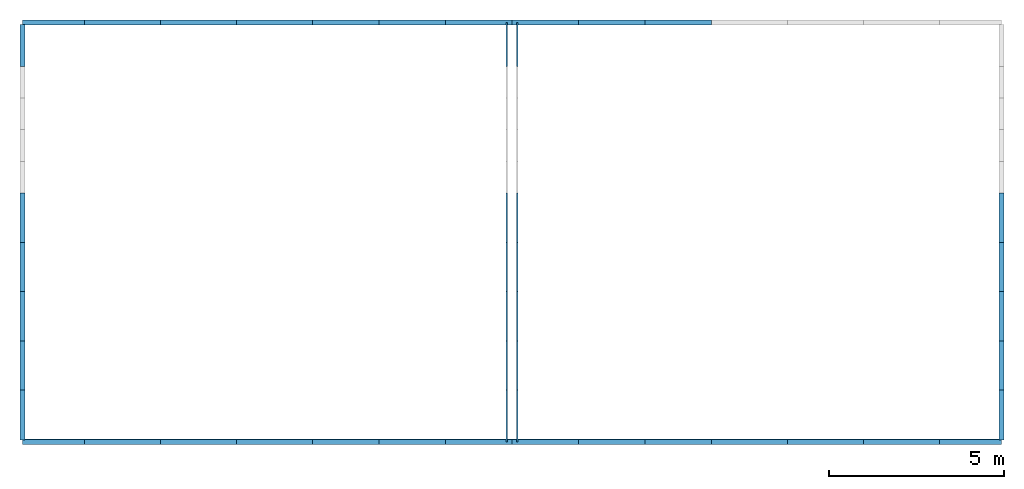
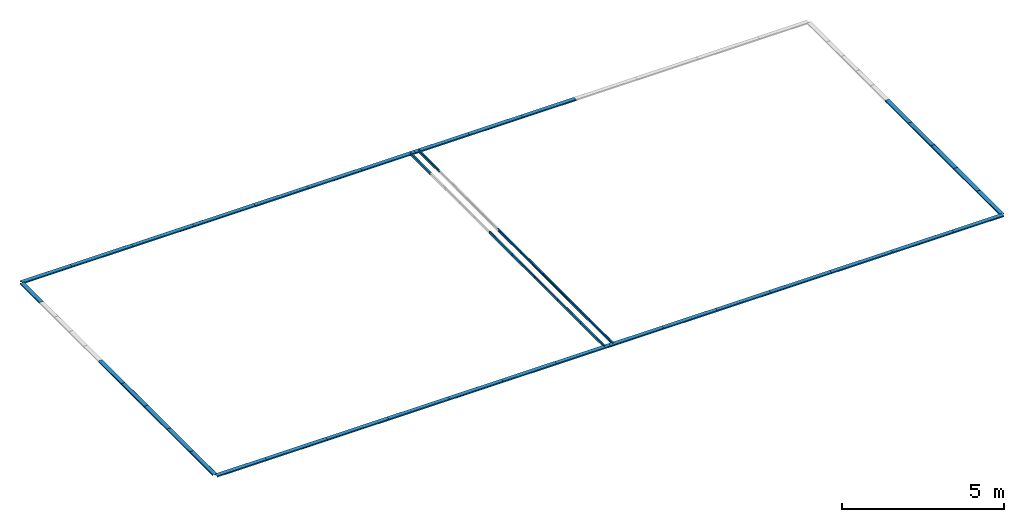
# One storey, part 1 of 2: 47 beams.
"""IFC4 building model written with IfcOpenShell, lengths in metres."""

import ifcopenshell
import ifcopenshell.guid

model = None  # the IFC model being written
_history = None  # IfcOwnerHistory: only IFC2X3 demands one
_inside = {}  # id of a spatial element -> (the spatial element, [elements in it])
_under = {}  # id of a project, library or spatial element -> (it, [spatial elements below it])
_declared = {}  # id of a project -> (the project, [libraries it declares])
_typed = {}  # id of a type object -> (the type object, [elements of that type])
_made_of = {}  # id of a material, layer set ... -> (it, [elements and type objects made of it])


def new_model(schema):
    """Start an empty IFC model of exactly this schema.

    Asked for "IFC4X3", IfcOpenShell would pick the latest addendum, in which some entities
    have other attributes; the version numbers below select the first issue.
    IFC2X3 requires an IfcOwnerHistory on every rooted entity: one is made here for all.
    """
    global model, _history
    if schema == "IFC4X3":
        model = ifcopenshell.file(schema_version=(4, 3, 0, 0))
    else:
        model = ifcopenshell.file(schema=schema)
    _inside.clear()
    _under.clear()
    _declared.clear()
    _typed.clear()
    _made_of.clear()
    _history = None
    if model.schema == "IFC2X3":
        org = make("IfcOrganization", Name="unknown")
        user = make(
            "IfcPersonAndOrganization",
            ThePerson=make("IfcPerson", FamilyName="unknown"),
            TheOrganization=org,
        )
        app = make(
            "IfcApplication",
            ApplicationDeveloper=org,
            Version="unknown",
            ApplicationFullName="unknown",
            ApplicationIdentifier="unknown",
        )
        _history = make(
            "IfcOwnerHistory",
            OwningUser=user,
            OwningApplication=app,
            ChangeAction="ADDED",
            CreationDate=0,
        )
    return model


def make(cls, **values):
    """One entity of the class cls with the attributes given. An attribute that is None is left unset."""
    return model.create_entity(
        cls, **{name: value for name, value in values.items() if value is not None}
    )


def rooted(cls, **values):
    """An entity with a GlobalId (a new one), such as an element, a storey or a relation."""
    return make(cls, GlobalId=ifcopenshell.guid.new(), OwnerHistory=_history, **values)


def si_unit(unit_type, name, prefix=None):
    """IfcSIUnit, for example si_unit("LENGTHUNIT", "METRE", prefix="MILLI")."""
    return make("IfcSIUnit", UnitType=unit_type, Prefix=prefix, Name=name)


def derived_unit(unit_type, elements):
    """IfcDerivedUnit: a product of units, each with its exponent."""
    return make(
        "IfcDerivedUnit",
        Elements=[
            make("IfcDerivedUnitElement", Unit=unit, Exponent=power)
            for unit, power in elements
        ],
        UnitType=unit_type,
    )


def assignment(units):
    """IfcUnitAssignment: the units of a project."""
    return None if units is None else make("IfcUnitAssignment", Units=units)


def point(xyz):
    """IfcCartesianPoint."""
    return None if xyz is None else make("IfcCartesianPoint", Coordinates=xyz)


def direction(xyz):
    """IfcDirection."""
    return None if xyz is None else make("IfcDirection", DirectionRatios=xyz)


def frame(location, z_axis=None, x_axis=None):
    """IfcAxis2Placement3D, a coordinate frame: its origin and axes. An axis left out is left unset."""
    return make(
        "IfcAxis2Placement3D",
        Location=point(location),
        Axis=direction(z_axis),
        RefDirection=direction(x_axis),
    )


def frame_2d(location, x_axis=None):
    """IfcAxis2Placement2D, a coordinate frame in the plane: its origin and x axis."""
    return make(
        "IfcAxis2Placement2D", Location=point(location), RefDirection=direction(x_axis)
    )


def origin_with_axes():
    """The frame at (0, 0, 0) with the z axis (0, 0, 1) and the x axis (1, 0, 0) written out."""
    return frame((0.0, 0.0, 0.0), z_axis=(0.0, 0.0, 1.0), x_axis=(1.0, 0.0, 0.0))


def origin_2d_with_axis():
    """The frame at (0, 0) in the plane with the x axis (1, 0) written out."""
    return frame_2d((0.0, 0.0), x_axis=(1.0, 0.0))


def place(relative_to, where):
    """IfcLocalPlacement: puts the frame where relative to a parent placement (None: the world)."""
    return make(
        "IfcLocalPlacement", PlacementRelTo=relative_to, RelativePlacement=where
    )


def context(
    kind, dimensions, precision=None, world=None, true_north=None, identifier=None
):
    """IfcGeometricRepresentationContext, for example the 3D "Model" context."""
    return make(
        "IfcGeometricRepresentationContext",
        ContextIdentifier=identifier,
        ContextType=kind,
        CoordinateSpaceDimension=dimensions,
        Precision=precision,
        WorldCoordinateSystem=world,
        TrueNorth=true_north,
    )


def project(units=None, contexts=None):
    """IfcProject with its units and contexts."""
    return rooted(
        "IfcProject",
        Name="project",
        RepresentationContexts=contexts,
        UnitsInContext=assignment(units),
    )


def spatial(cls, under=None, at=None, **own):
    """A site, building, storey or space (cls), placed at a placement, below another one or the project."""
    s = rooted(cls, ObjectPlacement=at, **own)
    if under is not None:
        _under.setdefault(under.id(), (under, []))[1].append(s)
    return s


def profile(cls, at=None, kind="AREA", **sizes):
    """A parametric profile (cls). Its sizes go by their IFC names, for example OverallWidth=200.0."""
    return make(cls, ProfileType=kind, Position=at, **sizes)


def c_section(**sizes):
    """IfcCShapeProfileDef."""
    return profile("IfcCShapeProfileDef", **sizes)


def extrude(swept, where, along, depth):
    """IfcExtrudedAreaSolid: the profile swept, set in the frame where, extruded along a direction by depth."""
    return make(
        "IfcExtrudedAreaSolid",
        SweptArea=swept,
        Position=where,
        ExtrudedDirection=direction(along),
        Depth=depth,
    )


def shape(context_of_items, identifier, shape_type, items):
    """IfcShapeRepresentation: the items that make up one representation, for example the "Body"."""
    return make(
        "IfcShapeRepresentation",
        ContextOfItems=context_of_items,
        RepresentationIdentifier=identifier,
        RepresentationType=shape_type,
        Items=items,
    )


def material(Name=None, Category=None):
    """IfcMaterial."""
    return make("IfcMaterial", Name=Name, Category=Category)


def material_profile(
    of_material, cross_section, Name=None, Category=None, Priority=None
):
    """IfcMaterialProfile: a cross section and its material."""
    return make(
        "IfcMaterialProfile",
        Name=Name,
        Material=of_material,
        Profile=cross_section,
        Priority=Priority,
        Category=Category,
    )


def profile_set(profiles, Name=None, composite=None):
    """IfcMaterialProfileSet."""
    return make(
        "IfcMaterialProfileSet",
        Name=Name,
        MaterialProfiles=profiles,
        CompositeProfile=composite,
    )


def profile_usage(for_profile_set, cardinal=None, extent=None):
    """IfcMaterialProfileSetUsage: how a profile set lies along its element."""
    return make(
        "IfcMaterialProfileSetUsage",
        ForProfileSet=for_profile_set,
        CardinalPoint=cardinal,
        ReferenceExtent=extent,
    )


def made_of(thing, what):
    """Note that an element or type object is made of a material, layer set ...; save() writes the relation."""
    if what is not None:
        _made_of.setdefault(what.id(), (what, []))[1].append(thing)
    return thing


def element(
    cls,
    number,
    at=None,
    inside=None,
    cuts=None,
    type_object=None,
    material=None,
    context=None,
    identifier="Body",
    shape_type=None,
    held_by="IfcProductDefinitionShape",
    body=None,
    shapes=None,
    **own,
):
    """One element of the class cls, such as IfcWall. Its Tag is "e" and its number.

    at: its placement. inside: the storey or other place that contains it. cuts: it is an
    opening in that element (IfcRelVoidsElement). A single representation is given by context,
    identifier, shape_type and body (its items); several are given by shapes. held_by: the class
    of the entity that holds the representations. save() writes the other relations.
    """
    e = rooted(cls, Tag="e%d" % number, ObjectPlacement=at, **own)
    if body is not None:
        shapes = [shape(context, identifier, shape_type, body)]
    if shapes is not None:
        e.Representation = make(held_by, Representations=shapes)
    if inside is not None:
        _inside.setdefault(inside.id(), (inside, []))[1].append(e)
    if cuts is not None:
        rooted(
            "IfcRelVoidsElement", RelatingBuildingElement=cuts, RelatedOpeningElement=e
        )
    if type_object is not None:
        _typed.setdefault(type_object.id(), (type_object, []))[1].append(e)
    return made_of(e, material)


def aggregate(whole, parts):
    """IfcRelAggregates: a whole, such as a stair, and the parts it consists of."""
    return rooted("IfcRelAggregates", RelatingObject=whole, RelatedObjects=parts)


def save(model, path):
    """Write the relations noted so far, then the file.

    IfcRelAggregates (storeys below a building ...), IfcRelContainedInSpatialStructure (elements
    in a storey), IfcRelDefinesByType, IfcRelAssociatesMaterial and IfcRelDeclares: one each for
    every whole, place, type object, material and project.
    """
    for whole, parts in _under.values():
        aggregate(whole, parts)
    for where, things in _inside.values():
        rooted(
            "IfcRelContainedInSpatialStructure",
            RelatedElements=things,
            RelatingStructure=where,
        )
    for kind, things in _typed.values():
        rooted("IfcRelDefinesByType", RelatedObjects=things, RelatingType=kind)
    for what, things in _made_of.values():
        rooted("IfcRelAssociatesMaterial", RelatedObjects=things, RelatingMaterial=what)
    for by, libraries in _declared.values():
        rooted("IfcRelDeclares", RelatingContext=by, RelatedDefinitions=libraries)
    model.write(path)


model = new_model("IFC4")

# Units and contexts
model_context = context("Model", 3, world=origin_with_axes())
ifc_project = project(units=[si_unit("LENGTHUNIT", "METRE"), si_unit("AREAUNIT", "SQUARE_METRE"), si_unit("VOLUMEUNIT", "CUBIC_METRE"), derived_unit("SECTIONMODULUSUNIT", [(si_unit("LENGTHUNIT", "METRE"), 3)]), derived_unit("MOMENTOFINERTIAUNIT", [(si_unit("LENGTHUNIT", "METRE"), 4)]), si_unit("PLANEANGLEUNIT", "RADIAN"), si_unit("TIMEUNIT", "SECOND"), si_unit("THERMODYNAMICTEMPERATUREUNIT", "DEGREE_CELSIUS"), derived_unit("THERMALEXPANSIONCOEFFICIENTUNIT", [(si_unit("THERMODYNAMICTEMPERATUREUNIT", "DEGREE_CELSIUS"), -1)])], contexts=[model_context])

# Site, building, storey
site = spatial("IfcSite", under=ifc_project, CompositionType="ELEMENT")
building = spatial("IfcBuilding", under=site, Name="Building", CompositionType="ELEMENT")
storey = spatial("IfcBuildingStorey", under=building, Name="TOP LEVEL", CompositionType="ELEMENT", Elevation=9.9498)

# Beams
ifc_material = material(Name="SAE 1020")
ifc_material_profile_1 = material_profile(ifc_material, c_section(Depth=0.1, Width=0.05, WallThickness=0.003, Girth=0.017, InternalFilletRadius=0.003, at=origin_2d_with_axis()))
ifc_profile_set_1 = profile_set([ifc_material_profile_1])
ifc_profile_usage_1 = profile_usage(ifc_profile_set_1, cardinal=10)
beam_1_placement = place(None, frame((15.1, 8.75, 9.9441), z_axis=(3.3783784e-07, 1.0, -3.0405405e-05), x_axis=(0.9992562, 8.3491316e-07, 0.038562213)))
element("IfcBeam", 1, at=beam_1_placement, inside=storey, material=ifc_profile_usage_1, Name="60", context=model_context, shape_type="SweptSolid", body=[
    extrude(c_section(Depth=0.1, Width=0.05, WallThickness=0.003, Girth=0.017, InternalFilletRadius=0.003, at=origin_2d_with_axis()), origin_with_axes(), (0.0, 0.0, 1.0), 1.48),
])
ifc_material_profile_2 = material_profile(ifc_material, c_section(Depth=0.1, Width=0.05, WallThickness=0.003, Girth=0.017, InternalFilletRadius=0.003, at=origin_2d_with_axis()))
ifc_profile_set_2 = profile_set([ifc_material_profile_2])
ifc_profile_usage_2 = profile_usage(ifc_profile_set_2, cardinal=10)
beam_2_placement = place(None, frame((15.1, 19.5, 9.9441136), z_axis=(3.3783784e-07, 1.0, -3.0405405e-05), x_axis=(0.9992562, 8.3491316e-07, 0.038562213)))
element("IfcBeam", 2, at=beam_2_placement, inside=storey, material=ifc_profile_usage_2, Name="65", context=model_context, shape_type="SweptSolid", body=[
    extrude(c_section(Depth=0.1, Width=0.05, WallThickness=0.003, Girth=0.017, InternalFilletRadius=0.003, at=origin_2d_with_axis()), origin_with_axes(), (0.0, 0.0, 1.0), 1.25),
])
ifc_material_profile_3 = material_profile(ifc_material, c_section(Depth=0.1, Width=0.05, WallThickness=0.003, Girth=0.017, InternalFilletRadius=0.003, at=origin_2d_with_axis()))
ifc_profile_set_3 = profile_set([ifc_material_profile_3])
ifc_profile_usage_3 = profile_usage(ifc_profile_set_3, cardinal=10)
beam_3_placement = place(None, frame((15.4, 8.75, 9.9441), z_axis=(3.3783784e-07, 1.0, -3.0405405e-05), x_axis=(-0.9992562, 8.3491316e-07, 0.038562213)))
element("IfcBeam", 3, at=beam_3_placement, inside=storey, material=ifc_profile_usage_3, Name="180", context=model_context, shape_type="SweptSolid", body=[
    extrude(c_section(Depth=0.1, Width=0.05, WallThickness=0.003, Girth=0.017, InternalFilletRadius=0.003, at=origin_2d_with_axis()), origin_with_axes(), (0.0, 0.0, 1.0), 1.48),
])
ifc_material_profile_4 = material_profile(ifc_material, c_section(Depth=0.1, Width=0.05, WallThickness=0.003, Girth=0.017, InternalFilletRadius=0.003, at=origin_2d_with_axis()))
ifc_profile_set_4 = profile_set([ifc_material_profile_4])
ifc_profile_usage_4 = profile_usage(ifc_profile_set_4, cardinal=10)
beam_4_placement = place(None, frame((15.4, 19.5, 9.9441136), z_axis=(3.3783784e-07, 1.0, -3.0405405e-05), x_axis=(-0.9992562, 8.3491316e-07, 0.038562213)))
element("IfcBeam", 4, at=beam_4_placement, inside=storey, material=ifc_profile_usage_4, Name="185", context=model_context, shape_type="SweptSolid", body=[
    extrude(c_section(Depth=0.1, Width=0.05, WallThickness=0.003, Girth=0.017, InternalFilletRadius=0.003, at=origin_2d_with_axis()), origin_with_axes(), (0.0, 0.0, 1.0), 1.25),
])
ifc_material_profile_5 = material_profile(ifc_material, c_section(Depth=0.1, Width=0.05, WallThickness=0.003, Girth=0.017, InternalFilletRadius=0.003, at=origin_2d_with_axis()))
ifc_profile_set_5 = profile_set([ifc_material_profile_5])
ifc_profile_usage_5 = profile_usage(ifc_profile_set_5, cardinal=10)
beam_5_placement = place(None, frame((15.1, 10.23, 9.9441004), z_axis=(3.3783784e-07, 1.0, -3.0405405e-05), x_axis=(0.9992562, 8.3491316e-07, 0.038562213)))
element("IfcBeam", 5, at=beam_5_placement, inside=storey, material=ifc_profile_usage_5, Name="508", context=model_context, shape_type="SweptSolid", body=[
    extrude(c_section(Depth=0.1, Width=0.05, WallThickness=0.003, Girth=0.017, InternalFilletRadius=0.003, at=origin_2d_with_axis()), origin_with_axes(), (0.0, 0.0, 1.0), 1.41),
])
ifc_material_profile_6 = material_profile(ifc_material, c_section(Depth=0.1, Width=0.05, WallThickness=0.003, Girth=0.017, InternalFilletRadius=0.003, at=origin_2d_with_axis()))
ifc_profile_set_6 = profile_set([ifc_material_profile_6])
ifc_profile_usage_6 = profile_usage(ifc_profile_set_6, cardinal=10)
beam_6_placement = place(None, frame((15.1, 11.64, 9.9441004), z_axis=(3.3783784e-07, 1.0, -3.0405405e-05), x_axis=(0.9992562, 8.3491316e-07, 0.038562213)))
element("IfcBeam", 6, at=beam_6_placement, inside=storey, material=ifc_profile_usage_6, Name="509", context=model_context, shape_type="SweptSolid", body=[
    extrude(c_section(Depth=0.1, Width=0.05, WallThickness=0.003, Girth=0.017, InternalFilletRadius=0.003, at=origin_2d_with_axis()), origin_with_axes(), (0.0, 0.0, 1.0), 1.41),
])
ifc_material_profile_7 = material_profile(ifc_material, c_section(Depth=0.1, Width=0.05, WallThickness=0.003, Girth=0.017, InternalFilletRadius=0.003, at=origin_2d_with_axis()))
ifc_profile_set_7 = profile_set([ifc_material_profile_7])
ifc_profile_usage_7 = profile_usage(ifc_profile_set_7, cardinal=10)
beam_7_placement = place(None, frame((15.1, 13.05, 9.9441004), z_axis=(3.3783784e-07, 1.0, -3.0405405e-05), x_axis=(0.9992562, 8.3491316e-07, 0.038562213)))
element("IfcBeam", 7, at=beam_7_placement, inside=storey, material=ifc_profile_usage_7, Name="511", context=model_context, shape_type="SweptSolid", body=[
    extrude(c_section(Depth=0.1, Width=0.05, WallThickness=0.003, Girth=0.017, InternalFilletRadius=0.003, at=origin_2d_with_axis()), origin_with_axes(), (0.0, 0.0, 1.0), 1.41),
])
ifc_material_profile_8 = material_profile(ifc_material, c_section(Depth=0.1, Width=0.05, WallThickness=0.003, Girth=0.017, InternalFilletRadius=0.003, at=origin_2d_with_axis()))
ifc_profile_set_8 = profile_set([ifc_material_profile_8])
ifc_profile_usage_8 = profile_usage(ifc_profile_set_8, cardinal=10)
beam_8_placement = place(None, frame((15.1, 14.46, 9.9441004), z_axis=(3.3783784e-07, 1.0, -3.0405405e-05), x_axis=(0.9992562, 8.3491316e-07, 0.038562213)))
element("IfcBeam", 8, at=beam_8_placement, inside=storey, material=ifc_profile_usage_8, Name="514", context=model_context, shape_type="SweptSolid", body=[
    extrude(c_section(Depth=0.1, Width=0.05, WallThickness=0.003, Girth=0.017, InternalFilletRadius=0.003, at=origin_2d_with_axis()), origin_with_axes(), (0.0, 0.0, 1.0), 1.41),
])
ifc_material_profile_9 = material_profile(ifc_material, c_section(Depth=0.1, Width=0.05, WallThickness=0.003, Girth=0.017, InternalFilletRadius=0.003, at=origin_2d_with_axis()))
ifc_profile_set_9 = profile_set([ifc_material_profile_9])
ifc_profile_usage_9 = profile_usage(ifc_profile_set_9, cardinal=10)
beam_9_placement = place(None, frame((15.4, 10.23, 9.9441004), z_axis=(3.3783784e-07, 1.0, -3.0405405e-05), x_axis=(-0.9992562, 8.3491316e-07, 0.038562213)))
element("IfcBeam", 9, at=beam_9_placement, inside=storey, material=ifc_profile_usage_9, Name="1011", context=model_context, shape_type="SweptSolid", body=[
    extrude(c_section(Depth=0.1, Width=0.05, WallThickness=0.003, Girth=0.017, InternalFilletRadius=0.003, at=origin_2d_with_axis()), origin_with_axes(), (0.0, 0.0, 1.0), 1.41),
])
ifc_material_profile_10 = material_profile(ifc_material, c_section(Depth=0.1, Width=0.05, WallThickness=0.003, Girth=0.017, InternalFilletRadius=0.003, at=origin_2d_with_axis()))
ifc_profile_set_10 = profile_set([ifc_material_profile_10])
ifc_profile_usage_10 = profile_usage(ifc_profile_set_10, cardinal=10)
beam_10_placement = place(None, frame((15.4, 11.64, 9.9441004), z_axis=(3.3783784e-07, 1.0, -3.0405405e-05), x_axis=(-0.9992562, 8.3491316e-07, 0.038562213)))
element("IfcBeam", 10, at=beam_10_placement, inside=storey, material=ifc_profile_usage_10, Name="1012", context=model_context, shape_type="SweptSolid", body=[
    extrude(c_section(Depth=0.1, Width=0.05, WallThickness=0.003, Girth=0.017, InternalFilletRadius=0.003, at=origin_2d_with_axis()), origin_with_axes(), (0.0, 0.0, 1.0), 1.41),
])
ifc_material_profile_11 = material_profile(ifc_material, c_section(Depth=0.1, Width=0.05, WallThickness=0.003, Girth=0.017, InternalFilletRadius=0.003, at=origin_2d_with_axis()))
ifc_profile_set_11 = profile_set([ifc_material_profile_11])
ifc_profile_usage_11 = profile_usage(ifc_profile_set_11, cardinal=10)
beam_11_placement = place(None, frame((15.4, 13.05, 9.9441004), z_axis=(3.3783784e-07, 1.0, -3.0405405e-05), x_axis=(-0.9992562, 8.3491316e-07, 0.038562213)))
element("IfcBeam", 11, at=beam_11_placement, inside=storey, material=ifc_profile_usage_11, Name="1013", context=model_context, shape_type="SweptSolid", body=[
    extrude(c_section(Depth=0.1, Width=0.05, WallThickness=0.003, Girth=0.017, InternalFilletRadius=0.003, at=origin_2d_with_axis()), origin_with_axes(), (0.0, 0.0, 1.0), 1.41),
])
ifc_material_profile_12 = material_profile(ifc_material, c_section(Depth=0.1, Width=0.05, WallThickness=0.003, Girth=0.017, InternalFilletRadius=0.003, at=origin_2d_with_axis()))
ifc_profile_set_12 = profile_set([ifc_material_profile_12])
ifc_profile_usage_12 = profile_usage(ifc_profile_set_12, cardinal=10)
beam_12_placement = place(None, frame((15.4, 14.46, 9.9441004), z_axis=(3.3783784e-07, 1.0, -3.0405405e-05), x_axis=(-0.9992562, 8.3491316e-07, 0.038562213)))
element("IfcBeam", 12, at=beam_12_placement, inside=storey, material=ifc_profile_usage_12, Name="1014", context=model_context, shape_type="SweptSolid", body=[
    extrude(c_section(Depth=0.1, Width=0.05, WallThickness=0.003, Girth=0.017, InternalFilletRadius=0.003, at=origin_2d_with_axis()), origin_with_axes(), (0.0, 0.0, 1.0), 1.41),
])
ifc_material_profile_13 = material_profile(ifc_material, c_section(Depth=0.15, Width=0.05, WallThickness=0.003, Girth=0.017, InternalFilletRadius=0.003, at=origin_2d_with_axis()))
ifc_profile_set_13 = profile_set([ifc_material_profile_13])
ifc_profile_usage_13 = profile_usage(ifc_profile_set_13, cardinal=10)
beam_13_placement = place(None, frame((1.2413995, 8.75, 9.9497), z_axis=(1.0, 0.0, 0.0), x_axis=(-9.5775484e-06, 0.0, -1.0)))
element("IfcBeam", 13, at=beam_13_placement, inside=storey, material=ifc_profile_usage_13, Name="942", context=model_context, shape_type="SweptSolid", body=[
    extrude(c_section(Depth=0.15, Width=0.05, WallThickness=0.003, Girth=0.017, InternalFilletRadius=0.003, at=origin_2d_with_axis()), origin_with_axes(), (0.0, 0.0, 1.0), 1.7749845),
])
ifc_material_profile_14 = material_profile(ifc_material, c_section(Depth=0.15, Width=0.05, WallThickness=0.003, Girth=0.017, InternalFilletRadius=0.003, at=origin_2d_with_axis()))
ifc_profile_set_14 = profile_set([ifc_material_profile_14])
ifc_profile_usage_14 = profile_usage(ifc_profile_set_14, cardinal=10)
beam_14_placement = place(None, frame((27.483584, 8.75, 9.949683), z_axis=(1.0, 0.0, 0.0), x_axis=(-9.5775484e-06, 0.0, -1.0)))
element("IfcBeam", 14, at=beam_14_placement, inside=storey, material=ifc_profile_usage_14, Name="946", context=model_context, shape_type="SweptSolid", body=[
    extrude(c_section(Depth=0.15, Width=0.05, WallThickness=0.003, Girth=0.017, InternalFilletRadius=0.003, at=origin_2d_with_axis()), origin_with_axes(), (0.0, 0.0, 1.0), 1.7750155),
])
ifc_material_profile_15 = material_profile(ifc_material, c_section(Depth=0.15, Width=0.05, WallThickness=0.003, Girth=0.017, InternalFilletRadius=0.003, at=origin_2d_with_axis()))
ifc_profile_set_15 = profile_set([ifc_material_profile_15])
ifc_profile_usage_15 = profile_usage(ifc_profile_set_15, cardinal=10)
beam_15_placement = place(None, frame((3.0164, 20.75, 9.949683), z_axis=(-1.0, 0.0, -9.5774675e-06), x_axis=(-9.5775484e-06, 0.0, -1.0)))
element("IfcBeam", 15, at=beam_15_placement, inside=storey, material=ifc_profile_usage_15, Name="954", context=model_context, shape_type="SweptSolid", body=[
    extrude(c_section(Depth=0.15, Width=0.05, WallThickness=0.003, Girth=0.017, InternalFilletRadius=0.003, at=origin_2d_with_axis()), origin_with_axes(), (0.0, 0.0, 1.0), 1.7750005),
])
ifc_material_profile_16 = material_profile(ifc_material, c_section(Depth=0.15, Width=0.05, WallThickness=0.003, Girth=0.017, InternalFilletRadius=0.003, at=origin_2d_with_axis()))
ifc_profile_set_16 = profile_set([ifc_material_profile_16])
ifc_profile_usage_16 = profile_usage(ifc_profile_set_16, cardinal=10)
beam_16_placement = place(None, frame((20.965601, 20.75, 9.9498), z_axis=(-1.0, 0.0, -9.5774675e-06), x_axis=(-9.5775484e-06, 0.0, -1.0)))
element("IfcBeam", 16, at=beam_16_placement, inside=storey, material=ifc_profile_usage_16, Name="1058", context=model_context, shape_type="SweptSolid", body=[
    extrude(c_section(Depth=0.15, Width=0.05, WallThickness=0.003, Girth=0.017, InternalFilletRadius=0.003, at=origin_2d_with_axis()), origin_with_axes(), (0.0, 0.0, 1.0), 1.9052002),
])
ifc_material_profile_17 = material_profile(ifc_material, c_section(Depth=0.15, Width=0.05, WallThickness=0.003, Girth=0.017, InternalFilletRadius=0.003, at=origin_2d_with_axis()))
ifc_profile_set_17 = profile_set([ifc_material_profile_17])
ifc_profile_usage_17 = profile_usage(ifc_profile_set_17, cardinal=10)
beam_17_placement = place(None, frame((19.0604, 20.750005, 9.9497667), z_axis=(-1.0, 0.0, -9.5774675e-06), x_axis=(-9.5775484e-06, 0.0, -1.0)))
element("IfcBeam", 17, at=beam_17_placement, inside=storey, material=ifc_profile_usage_17, Name="1059", context=model_context, shape_type="SweptSolid", body=[
    extrude(c_section(Depth=0.15, Width=0.05, WallThickness=0.003, Girth=0.017, InternalFilletRadius=0.003, at=origin_2d_with_axis()), origin_with_axes(), (0.0, 0.0, 1.0), 1.9052002),
])
ifc_material_profile_18 = material_profile(ifc_material, c_section(Depth=0.15, Width=0.05, WallThickness=0.003, Girth=0.017, InternalFilletRadius=0.003, at=origin_2d_with_axis()))
ifc_profile_set_18 = profile_set([ifc_material_profile_18])
ifc_profile_usage_18 = profile_usage(ifc_profile_set_18, cardinal=10)
beam_18_placement = place(None, frame((17.1552, 20.750011, 9.9497333), z_axis=(-1.0, 0.0, -9.5774675e-06), x_axis=(-9.5775484e-06, 0.0, -1.0)))
element("IfcBeam", 18, at=beam_18_placement, inside=storey, material=ifc_profile_usage_18, Name="1064", context=model_context, shape_type="SweptSolid", body=[
    extrude(c_section(Depth=0.15, Width=0.05, WallThickness=0.003, Girth=0.017, InternalFilletRadius=0.003, at=origin_2d_with_axis()), origin_with_axes(), (0.0, 0.0, 1.0), 1.9052002),
])
ifc_material_profile_19 = material_profile(ifc_material, c_section(Depth=0.15, Width=0.05, WallThickness=0.003, Girth=0.017, InternalFilletRadius=0.003, at=origin_2d_with_axis()))
ifc_profile_set_19 = profile_set([ifc_material_profile_19])
ifc_profile_usage_19 = profile_usage(ifc_profile_set_19, cardinal=10)
beam_19_placement = place(None, frame((15.25, 20.750016, 9.949738), z_axis=(-1.0, 0.0, -9.5774675e-06), x_axis=(-9.5775484e-06, 0.0, -1.0)))
element("IfcBeam", 19, at=beam_19_placement, inside=storey, material=ifc_profile_usage_19, Name="1066", context=model_context, shape_type="SweptSolid", body=[
    extrude(c_section(Depth=0.15, Width=0.05, WallThickness=0.003, Girth=0.017, InternalFilletRadius=0.003, at=origin_2d_with_axis()), origin_with_axes(), (0.0, 0.0, 1.0), 1.9052002),
])
ifc_material_profile_20 = material_profile(ifc_material, c_section(Depth=0.15, Width=0.05, WallThickness=0.003, Girth=0.017, InternalFilletRadius=0.003, at=origin_2d_with_axis()))
ifc_profile_set_20 = profile_set([ifc_material_profile_20])
ifc_profile_usage_20 = profile_usage(ifc_profile_set_20, cardinal=10)
beam_20_placement = place(None, frame((13.3448, 20.750011, 9.9497333), z_axis=(-1.0, 0.0, -9.5774675e-06), x_axis=(-9.5775484e-06, 0.0, -1.0)))
element("IfcBeam", 20, at=beam_20_placement, inside=storey, material=ifc_profile_usage_20, Name="1067", context=model_context, shape_type="SweptSolid", body=[
    extrude(c_section(Depth=0.15, Width=0.05, WallThickness=0.003, Girth=0.017, InternalFilletRadius=0.003, at=origin_2d_with_axis()), origin_with_axes(), (0.0, 0.0, 1.0), 1.9052002),
])
ifc_material_profile_21 = material_profile(ifc_material, c_section(Depth=0.15, Width=0.05, WallThickness=0.003, Girth=0.017, InternalFilletRadius=0.003, at=origin_2d_with_axis()))
ifc_profile_set_21 = profile_set([ifc_material_profile_21])
ifc_profile_usage_21 = profile_usage(ifc_profile_set_21, cardinal=10)
beam_21_placement = place(None, frame((11.4396, 20.750005, 9.9497667), z_axis=(-1.0, 0.0, -9.5774675e-06), x_axis=(-9.5775484e-06, 0.0, -1.0)))
element("IfcBeam", 21, at=beam_21_placement, inside=storey, material=ifc_profile_usage_21, Name="1068", context=model_context, shape_type="SweptSolid", body=[
    extrude(c_section(Depth=0.15, Width=0.05, WallThickness=0.003, Girth=0.017, InternalFilletRadius=0.003, at=origin_2d_with_axis()), origin_with_axes(), (0.0, 0.0, 1.0), 1.9052002),
])
ifc_material_profile_22 = material_profile(ifc_material, c_section(Depth=0.15, Width=0.05, WallThickness=0.003, Girth=0.017, InternalFilletRadius=0.003, at=origin_2d_with_axis()))
ifc_profile_set_22 = profile_set([ifc_material_profile_22])
ifc_profile_usage_22 = profile_usage(ifc_profile_set_22, cardinal=10)
beam_22_placement = place(None, frame((9.5343995, 20.75, 9.9498), z_axis=(-1.0, 0.0, -9.5774675e-06), x_axis=(-9.5775484e-06, 0.0, -1.0)))
element("IfcBeam", 22, at=beam_22_placement, inside=storey, material=ifc_profile_usage_22, Name="1069", context=model_context, shape_type="SweptSolid", body=[
    extrude(c_section(Depth=0.15, Width=0.05, WallThickness=0.003, Girth=0.017, InternalFilletRadius=0.003, at=origin_2d_with_axis()), origin_with_axes(), (0.0, 0.0, 1.0), 2.1726665),
])
ifc_material_profile_23 = material_profile(ifc_material, c_section(Depth=0.15, Width=0.05, WallThickness=0.003, Girth=0.017, InternalFilletRadius=0.003, at=origin_2d_with_axis()))
ifc_profile_set_23 = profile_set([ifc_material_profile_23])
ifc_profile_usage_23 = profile_usage(ifc_profile_set_23, cardinal=10)
beam_23_placement = place(None, frame((7.361733, 20.75, 9.949761), z_axis=(-1.0, 0.0, -9.5774675e-06), x_axis=(-9.5775484e-06, 0.0, -1.0)))
element("IfcBeam", 23, at=beam_23_placement, inside=storey, material=ifc_profile_usage_23, Name="1071", context=model_context, shape_type="SweptSolid", body=[
    extrude(c_section(Depth=0.15, Width=0.05, WallThickness=0.003, Girth=0.017, InternalFilletRadius=0.003, at=origin_2d_with_axis()), origin_with_axes(), (0.0, 0.0, 1.0), 2.1726665),
])
ifc_material_profile_24 = material_profile(ifc_material, c_section(Depth=0.15, Width=0.05, WallThickness=0.003, Girth=0.017, InternalFilletRadius=0.003, at=origin_2d_with_axis()))
ifc_profile_set_24 = profile_set([ifc_material_profile_24])
ifc_profile_usage_24 = profile_usage(ifc_profile_set_24, cardinal=10)
beam_24_placement = place(None, frame((5.1890665, 20.75, 9.949722), z_axis=(-1.0, 0.0, -9.5774675e-06), x_axis=(-9.5775484e-06, 0.0, -1.0)))
element("IfcBeam", 24, at=beam_24_placement, inside=storey, material=ifc_profile_usage_24, Name="1073", context=model_context, shape_type="SweptSolid", body=[
    extrude(c_section(Depth=0.15, Width=0.05, WallThickness=0.003, Girth=0.017, InternalFilletRadius=0.003, at=origin_2d_with_axis()), origin_with_axes(), (0.0, 0.0, 1.0), 2.1726665),
])
ifc_material_profile_25 = material_profile(ifc_material, c_section(Depth=0.15, Width=0.05, WallThickness=0.003, Girth=0.017, InternalFilletRadius=0.003, at=origin_2d_with_axis()))
ifc_profile_set_25 = profile_set([ifc_material_profile_25])
ifc_profile_usage_25 = profile_usage(ifc_profile_set_25, cardinal=10)
beam_25_placement = place(None, frame((3.016384, 8.75, 9.949683), z_axis=(1.0, 0.0, 0.0), x_axis=(-9.5775484e-06, 0.0, -1.0)))
element("IfcBeam", 25, at=beam_25_placement, inside=storey, material=ifc_profile_usage_25, Name="1075", context=model_context, shape_type="SweptSolid", body=[
    extrude(c_section(Depth=0.15, Width=0.05, WallThickness=0.003, Girth=0.017, InternalFilletRadius=0.003, at=origin_2d_with_axis()), origin_with_axes(), (0.0, 0.0, 1.0), 2.1726825),
])
ifc_material_profile_26 = material_profile(ifc_material, c_section(Depth=0.15, Width=0.05, WallThickness=0.003, Girth=0.017, InternalFilletRadius=0.003, at=origin_2d_with_axis()))
ifc_profile_set_26 = profile_set([ifc_material_profile_26])
ifc_profile_usage_26 = profile_usage(ifc_profile_set_26, cardinal=10)
beam_26_placement = place(None, frame((5.1890665, 8.75, 9.949722), z_axis=(1.0, 0.0, 0.0), x_axis=(-9.5775484e-06, 0.0, -1.0)))
element("IfcBeam", 26, at=beam_26_placement, inside=storey, material=ifc_profile_usage_26, Name="1076", context=model_context, shape_type="SweptSolid", body=[
    extrude(c_section(Depth=0.15, Width=0.05, WallThickness=0.003, Girth=0.017, InternalFilletRadius=0.003, at=origin_2d_with_axis()), origin_with_axes(), (0.0, 0.0, 1.0), 2.1726665),
])
ifc_material_profile_27 = material_profile(ifc_material, c_section(Depth=0.15, Width=0.05, WallThickness=0.003, Girth=0.017, InternalFilletRadius=0.003, at=origin_2d_with_axis()))
ifc_profile_set_27 = profile_set([ifc_material_profile_27])
ifc_profile_usage_27 = profile_usage(ifc_profile_set_27, cardinal=10)
beam_27_placement = place(None, frame((7.361733, 8.75, 9.949761), z_axis=(1.0, 0.0, 0.0), x_axis=(-9.5775484e-06, 0.0, -1.0)))
element("IfcBeam", 27, at=beam_27_placement, inside=storey, material=ifc_profile_usage_27, Name="1077", context=model_context, shape_type="SweptSolid", body=[
    extrude(c_section(Depth=0.15, Width=0.05, WallThickness=0.003, Girth=0.017, InternalFilletRadius=0.003, at=origin_2d_with_axis()), origin_with_axes(), (0.0, 0.0, 1.0), 2.1726665),
])
ifc_material_profile_28 = material_profile(ifc_material, c_section(Depth=0.15, Width=0.05, WallThickness=0.003, Girth=0.017, InternalFilletRadius=0.003, at=origin_2d_with_axis()))
ifc_profile_set_28 = profile_set([ifc_material_profile_28])
ifc_profile_usage_28 = profile_usage(ifc_profile_set_28, cardinal=10)
beam_28_placement = place(None, frame((9.5343995, 8.75, 9.9498), z_axis=(1.0, 0.0, 0.0), x_axis=(-9.5775484e-06, 0.0, -1.0)))
element("IfcBeam", 28, at=beam_28_placement, inside=storey, material=ifc_profile_usage_28, Name="1078", context=model_context, shape_type="SweptSolid", body=[
    extrude(c_section(Depth=0.15, Width=0.05, WallThickness=0.003, Girth=0.017, InternalFilletRadius=0.003, at=origin_2d_with_axis()), origin_with_axes(), (0.0, 0.0, 1.0), 1.9052002),
])
ifc_material_profile_29 = material_profile(ifc_material, c_section(Depth=0.15, Width=0.05, WallThickness=0.003, Girth=0.017, InternalFilletRadius=0.003, at=origin_2d_with_axis()))
ifc_profile_set_29 = profile_set([ifc_material_profile_29])
ifc_profile_usage_29 = profile_usage(ifc_profile_set_29, cardinal=10)
beam_29_placement = place(None, frame((11.4396, 8.7500053, 9.9497667), z_axis=(1.0, 0.0, 0.0), x_axis=(-9.5775484e-06, 0.0, -1.0)))
element("IfcBeam", 29, at=beam_29_placement, inside=storey, material=ifc_profile_usage_29, Name="1080", context=model_context, shape_type="SweptSolid", body=[
    extrude(c_section(Depth=0.15, Width=0.05, WallThickness=0.003, Girth=0.017, InternalFilletRadius=0.003, at=origin_2d_with_axis()), origin_with_axes(), (0.0, 0.0, 1.0), 1.9052002),
])
ifc_material_profile_30 = material_profile(ifc_material, c_section(Depth=0.15, Width=0.05, WallThickness=0.003, Girth=0.017, InternalFilletRadius=0.003, at=origin_2d_with_axis()))
ifc_profile_set_30 = profile_set([ifc_material_profile_30])
ifc_profile_usage_30 = profile_usage(ifc_profile_set_30, cardinal=10)
beam_30_placement = place(None, frame((13.3448, 8.7500107, 9.9497333), z_axis=(1.0, 0.0, 0.0), x_axis=(-9.5775484e-06, 0.0, -1.0)))
element("IfcBeam", 30, at=beam_30_placement, inside=storey, material=ifc_profile_usage_30, Name="1081", context=model_context, shape_type="SweptSolid", body=[
    extrude(c_section(Depth=0.15, Width=0.05, WallThickness=0.003, Girth=0.017, InternalFilletRadius=0.003, at=origin_2d_with_axis()), origin_with_axes(), (0.0, 0.0, 1.0), 1.9051842),
])
ifc_material_profile_31 = material_profile(ifc_material, c_section(Depth=0.15, Width=0.05, WallThickness=0.003, Girth=0.017, InternalFilletRadius=0.003, at=origin_2d_with_axis()))
ifc_profile_set_31 = profile_set([ifc_material_profile_31])
ifc_profile_usage_31 = profile_usage(ifc_profile_set_31, cardinal=10)
beam_31_placement = place(None, frame((15.249984, 8.750016, 9.9496954), z_axis=(1.0, 0.0, 0.0), x_axis=(-9.5775484e-06, 0.0, -1.0)))
element("IfcBeam", 31, at=beam_31_placement, inside=storey, material=ifc_profile_usage_31, Name="1082", context=model_context, shape_type="SweptSolid", body=[
    extrude(c_section(Depth=0.15, Width=0.05, WallThickness=0.003, Girth=0.017, InternalFilletRadius=0.003, at=origin_2d_with_axis()), origin_with_axes(), (0.0, 0.0, 1.0), 1.9052162),
])
ifc_material_profile_32 = material_profile(ifc_material, c_section(Depth=0.15, Width=0.05, WallThickness=0.003, Girth=0.017, InternalFilletRadius=0.003, at=origin_2d_with_axis()))
ifc_profile_set_32 = profile_set([ifc_material_profile_32])
ifc_profile_usage_32 = profile_usage(ifc_profile_set_32, cardinal=10)
beam_32_placement = place(None, frame((17.1552, 8.7500107, 9.9497333), z_axis=(1.0, 0.0, 0.0), x_axis=(-9.5775484e-06, 0.0, -1.0)))
element("IfcBeam", 32, at=beam_32_placement, inside=storey, material=ifc_profile_usage_32, Name="1083", context=model_context, shape_type="SweptSolid", body=[
    extrude(c_section(Depth=0.15, Width=0.05, WallThickness=0.003, Girth=0.017, InternalFilletRadius=0.003, at=origin_2d_with_axis()), origin_with_axes(), (0.0, 0.0, 1.0), 1.9052002),
])
ifc_material_profile_33 = material_profile(ifc_material, c_section(Depth=0.15, Width=0.05, WallThickness=0.003, Girth=0.017, InternalFilletRadius=0.003, at=origin_2d_with_axis()))
ifc_profile_set_33 = profile_set([ifc_material_profile_33])
ifc_profile_usage_33 = profile_usage(ifc_profile_set_33, cardinal=10)
beam_33_placement = place(None, frame((19.0604, 8.7500053, 9.9497667), z_axis=(1.0, 0.0, 0.0), x_axis=(-9.5775484e-06, 0.0, -1.0)))
element("IfcBeam", 33, at=beam_33_placement, inside=storey, material=ifc_profile_usage_33, Name="1084", context=model_context, shape_type="SweptSolid", body=[
    extrude(c_section(Depth=0.15, Width=0.05, WallThickness=0.003, Girth=0.017, InternalFilletRadius=0.003, at=origin_2d_with_axis()), origin_with_axes(), (0.0, 0.0, 1.0), 1.9052002),
])
ifc_material_profile_34 = material_profile(ifc_material, c_section(Depth=0.15, Width=0.05, WallThickness=0.003, Girth=0.017, InternalFilletRadius=0.003, at=origin_2d_with_axis()))
ifc_profile_set_34 = profile_set([ifc_material_profile_34])
ifc_profile_usage_34 = profile_usage(ifc_profile_set_34, cardinal=10)
beam_34_placement = place(None, frame((20.965601, 8.75, 9.9498), z_axis=(1.0, 0.0, 0.0), x_axis=(-9.5775484e-06, 0.0, -1.0)))
element("IfcBeam", 34, at=beam_34_placement, inside=storey, material=ifc_profile_usage_34, Name="1085", context=model_context, shape_type="SweptSolid", body=[
    extrude(c_section(Depth=0.15, Width=0.05, WallThickness=0.003, Girth=0.017, InternalFilletRadius=0.003, at=origin_2d_with_axis()), origin_with_axes(), (0.0, 0.0, 1.0), 2.1726665),
])
ifc_material_profile_35 = material_profile(ifc_material, c_section(Depth=0.15, Width=0.05, WallThickness=0.003, Girth=0.017, InternalFilletRadius=0.003, at=origin_2d_with_axis()))
ifc_profile_set_35 = profile_set([ifc_material_profile_35])
ifc_profile_usage_35 = profile_usage(ifc_profile_set_35, cardinal=10)
beam_35_placement = place(None, frame((23.138267, 8.75, 9.949761), z_axis=(1.0, 0.0, 0.0), x_axis=(-9.5775484e-06, 0.0, -1.0)))
element("IfcBeam", 35, at=beam_35_placement, inside=storey, material=ifc_profile_usage_35, Name="1086", context=model_context, shape_type="SweptSolid", body=[
    extrude(c_section(Depth=0.15, Width=0.05, WallThickness=0.003, Girth=0.017, InternalFilletRadius=0.003, at=origin_2d_with_axis()), origin_with_axes(), (0.0, 0.0, 1.0), 2.1726665),
])
ifc_material_profile_36 = material_profile(ifc_material, c_section(Depth=0.15, Width=0.05, WallThickness=0.003, Girth=0.017, InternalFilletRadius=0.003, at=origin_2d_with_axis()))
ifc_profile_set_36 = profile_set([ifc_material_profile_36])
ifc_profile_usage_36 = profile_usage(ifc_profile_set_36, cardinal=10)
beam_36_placement = place(None, frame((25.310934, 8.75, 9.949722), z_axis=(1.0, 0.0, 0.0), x_axis=(-9.5775484e-06, 0.0, -1.0)))
element("IfcBeam", 36, at=beam_36_placement, inside=storey, material=ifc_profile_usage_36, Name="1087", context=model_context, shape_type="SweptSolid", body=[
    extrude(c_section(Depth=0.15, Width=0.05, WallThickness=0.003, Girth=0.017, InternalFilletRadius=0.003, at=origin_2d_with_axis()), origin_with_axes(), (0.0, 0.0, 1.0), 2.1726505),
])
ifc_material_profile_37 = material_profile(ifc_material, c_section(Depth=0.15, Width=0.05, WallThickness=0.003, Girth=0.017, InternalFilletRadius=0.003, at=origin_2d_with_axis()))
ifc_profile_set_37 = profile_set([ifc_material_profile_37])
ifc_profile_usage_37 = profile_usage(ifc_profile_set_37, cardinal=10)
beam_37_placement = place(None, frame((1.2414, 10.23, 9.9497), z_axis=(3.3783784e-07, 1.0, -3.0405405e-05), x_axis=(-9.5775484e-06, 0.0, -1.0)))
element("IfcBeam", 37, at=beam_37_placement, inside=storey, material=ifc_profile_usage_37, Name="1093", context=model_context, shape_type="SweptSolid", body=[
    extrude(c_section(Depth=0.15, Width=0.05, WallThickness=0.003, Girth=0.017, InternalFilletRadius=0.003, at=origin_2d_with_axis()), origin_with_axes(), (0.0, 0.0, 1.0), 1.41),
])
ifc_material_profile_38 = material_profile(ifc_material, c_section(Depth=0.15, Width=0.05, WallThickness=0.003, Girth=0.017, InternalFilletRadius=0.003, at=origin_2d_with_axis()))
ifc_profile_set_38 = profile_set([ifc_material_profile_38])
ifc_profile_usage_38 = profile_usage(ifc_profile_set_38, cardinal=10)
beam_38_placement = place(None, frame((1.2414, 11.64, 9.9497), z_axis=(3.3783784e-07, 1.0, -3.0405405e-05), x_axis=(-9.5775484e-06, 0.0, -1.0)))
element("IfcBeam", 38, at=beam_38_placement, inside=storey, material=ifc_profile_usage_38, Name="1094", context=model_context, shape_type="SweptSolid", body=[
    extrude(c_section(Depth=0.15, Width=0.05, WallThickness=0.003, Girth=0.017, InternalFilletRadius=0.003, at=origin_2d_with_axis()), origin_with_axes(), (0.0, 0.0, 1.0), 1.41),
])
ifc_material_profile_39 = material_profile(ifc_material, c_section(Depth=0.15, Width=0.05, WallThickness=0.003, Girth=0.017, InternalFilletRadius=0.003, at=origin_2d_with_axis()))
ifc_profile_set_39 = profile_set([ifc_material_profile_39])
ifc_profile_usage_39 = profile_usage(ifc_profile_set_39, cardinal=10)
beam_39_placement = place(None, frame((1.2414, 13.05, 9.9497), z_axis=(3.3783784e-07, 1.0, -3.0405405e-05), x_axis=(-9.5775484e-06, 0.0, -1.0)))
element("IfcBeam", 39, at=beam_39_placement, inside=storey, material=ifc_profile_usage_39, Name="1095", context=model_context, shape_type="SweptSolid", body=[
    extrude(c_section(Depth=0.15, Width=0.05, WallThickness=0.003, Girth=0.017, InternalFilletRadius=0.003, at=origin_2d_with_axis()), origin_with_axes(), (0.0, 0.0, 1.0), 1.41),
])
ifc_material_profile_40 = material_profile(ifc_material, c_section(Depth=0.15, Width=0.05, WallThickness=0.003, Girth=0.017, InternalFilletRadius=0.003, at=origin_2d_with_axis()))
ifc_profile_set_40 = profile_set([ifc_material_profile_40])
ifc_profile_usage_40 = profile_usage(ifc_profile_set_40, cardinal=10)
beam_40_placement = place(None, frame((1.2414, 14.46, 9.9497), z_axis=(3.3783784e-07, 1.0, -3.0405405e-05), x_axis=(-9.5775484e-06, 0.0, -1.0)))
element("IfcBeam", 40, at=beam_40_placement, inside=storey, material=ifc_profile_usage_40, Name="1097", context=model_context, shape_type="SweptSolid", body=[
    extrude(c_section(Depth=0.15, Width=0.05, WallThickness=0.003, Girth=0.017, InternalFilletRadius=0.003, at=origin_2d_with_axis()), origin_with_axes(), (0.0, 0.0, 1.0), 1.41),
])
ifc_material_profile_41 = material_profile(ifc_material, c_section(Depth=0.15, Width=0.05, WallThickness=0.003, Girth=0.017, InternalFilletRadius=0.003, at=origin_2d_with_axis()))
ifc_profile_set_41 = profile_set([ifc_material_profile_41])
ifc_profile_usage_41 = profile_usage(ifc_profile_set_41, cardinal=10)
beam_41_placement = place(None, frame((29.2586, 10.23, 9.9497), z_axis=(3.3783784e-07, 1.0, -3.0405405e-05), x_axis=(-9.5775484e-06, 0.0, -1.0)))
element("IfcBeam", 41, at=beam_41_placement, inside=storey, material=ifc_profile_usage_41, Name="1103", context=model_context, shape_type="SweptSolid", body=[
    extrude(c_section(Depth=0.15, Width=0.05, WallThickness=0.003, Girth=0.017, InternalFilletRadius=0.003, at=origin_2d_with_axis()), origin_with_axes(), (0.0, 0.0, 1.0), 1.41),
])
ifc_material_profile_42 = material_profile(ifc_material, c_section(Depth=0.15, Width=0.05, WallThickness=0.003, Girth=0.017, InternalFilletRadius=0.003, at=origin_2d_with_axis()))
ifc_profile_set_42 = profile_set([ifc_material_profile_42])
ifc_profile_usage_42 = profile_usage(ifc_profile_set_42, cardinal=10)
beam_42_placement = place(None, frame((29.2586, 11.64, 9.9497), z_axis=(3.3783784e-07, 1.0, -3.0405405e-05), x_axis=(-9.5775484e-06, 0.0, -1.0)))
element("IfcBeam", 42, at=beam_42_placement, inside=storey, material=ifc_profile_usage_42, Name="1104", context=model_context, shape_type="SweptSolid", body=[
    extrude(c_section(Depth=0.15, Width=0.05, WallThickness=0.003, Girth=0.017, InternalFilletRadius=0.003, at=origin_2d_with_axis()), origin_with_axes(), (0.0, 0.0, 1.0), 1.41),
])
ifc_material_profile_43 = material_profile(ifc_material, c_section(Depth=0.15, Width=0.05, WallThickness=0.003, Girth=0.017, InternalFilletRadius=0.003, at=origin_2d_with_axis()))
ifc_profile_set_43 = profile_set([ifc_material_profile_43])
ifc_profile_usage_43 = profile_usage(ifc_profile_set_43, cardinal=10)
beam_43_placement = place(None, frame((29.2586, 13.05, 9.9497), z_axis=(3.3783784e-07, 1.0, -3.0405405e-05), x_axis=(-9.5775484e-06, 0.0, -1.0)))
element("IfcBeam", 43, at=beam_43_placement, inside=storey, material=ifc_profile_usage_43, Name="1105", context=model_context, shape_type="SweptSolid", body=[
    extrude(c_section(Depth=0.15, Width=0.05, WallThickness=0.003, Girth=0.017, InternalFilletRadius=0.003, at=origin_2d_with_axis()), origin_with_axes(), (0.0, 0.0, 1.0), 1.41),
])
ifc_material_profile_44 = material_profile(ifc_material, c_section(Depth=0.15, Width=0.05, WallThickness=0.003, Girth=0.017, InternalFilletRadius=0.003, at=origin_2d_with_axis()))
ifc_profile_set_44 = profile_set([ifc_material_profile_44])
ifc_profile_usage_44 = profile_usage(ifc_profile_set_44, cardinal=10)
beam_44_placement = place(None, frame((29.2586, 14.46, 9.9497), z_axis=(3.3783784e-07, 1.0, -3.0405405e-05), x_axis=(-9.5775484e-06, 0.0, -1.0)))
element("IfcBeam", 44, at=beam_44_placement, inside=storey, material=ifc_profile_usage_44, Name="1107", context=model_context, shape_type="SweptSolid", body=[
    extrude(c_section(Depth=0.15, Width=0.05, WallThickness=0.003, Girth=0.017, InternalFilletRadius=0.003, at=origin_2d_with_axis()), origin_with_axes(), (0.0, 0.0, 1.0), 1.41),
])
ifc_material_profile_45 = material_profile(ifc_material, c_section(Depth=0.15, Width=0.05, WallThickness=0.003, Girth=0.017, InternalFilletRadius=0.003, at=origin_2d_with_axis()))
ifc_profile_set_45 = profile_set([ifc_material_profile_45])
ifc_profile_usage_45 = profile_usage(ifc_profile_set_45, cardinal=10)
beam_45_placement = place(None, frame((1.2413995, 8.8, 9.9497), z_axis=(3.3783784e-07, 1.0, -3.0405405e-05), x_axis=(-9.5775484e-06, 0.0, -1.0)))
element("IfcBeam", 45, at=beam_45_placement, inside=storey, material=ifc_profile_usage_45, Name="2144", context=model_context, shape_type="SweptSolid", body=[
    extrude(c_section(Depth=0.15, Width=0.05, WallThickness=0.003, Girth=0.017, InternalFilletRadius=0.003, at=origin_2d_with_axis()), origin_with_axes(), (0.0, 0.0, 1.0), 1.43),
])
ifc_material_profile_46 = material_profile(ifc_material, c_section(Depth=0.15, Width=0.05, WallThickness=0.003, Girth=0.017, InternalFilletRadius=0.003, at=origin_2d_with_axis()))
ifc_profile_set_46 = profile_set([ifc_material_profile_46])
ifc_profile_usage_46 = profile_usage(ifc_profile_set_46, cardinal=10)
beam_46_placement = place(None, frame((1.2414, 19.5, 9.9497), z_axis=(3.3783784e-07, 1.0, -3.0405405e-05), x_axis=(-9.5775484e-06, 0.0, -1.0)))
element("IfcBeam", 46, at=beam_46_placement, inside=storey, material=ifc_profile_usage_46, Name="2145", context=model_context, shape_type="SweptSolid", body=[
    extrude(c_section(Depth=0.15, Width=0.05, WallThickness=0.003, Girth=0.017, InternalFilletRadius=0.003, at=origin_2d_with_axis()), origin_with_axes(), (0.0, 0.0, 1.0), 1.2),
])
ifc_material_profile_47 = material_profile(ifc_material, c_section(Depth=0.15, Width=0.05, WallThickness=0.003, Girth=0.017, InternalFilletRadius=0.003, at=origin_2d_with_axis()))
ifc_profile_set_47 = profile_set([ifc_material_profile_47])
ifc_profile_usage_47 = profile_usage(ifc_profile_set_47, cardinal=10)
beam_47_placement = place(None, frame((29.258599, 8.8, 9.9497), z_axis=(3.3783784e-07, 1.0, -3.0405405e-05), x_axis=(-9.5775484e-06, 0.0, -1.0)))
element("IfcBeam", 47, at=beam_47_placement, inside=storey, material=ifc_profile_usage_47, Name="2170", context=model_context, shape_type="SweptSolid", body=[
    extrude(c_section(Depth=0.15, Width=0.05, WallThickness=0.003, Girth=0.017, InternalFilletRadius=0.003, at=origin_2d_with_axis()), origin_with_axes(), (0.0, 0.0, 1.0), 1.43),
])

save(model, "model.ifc")
